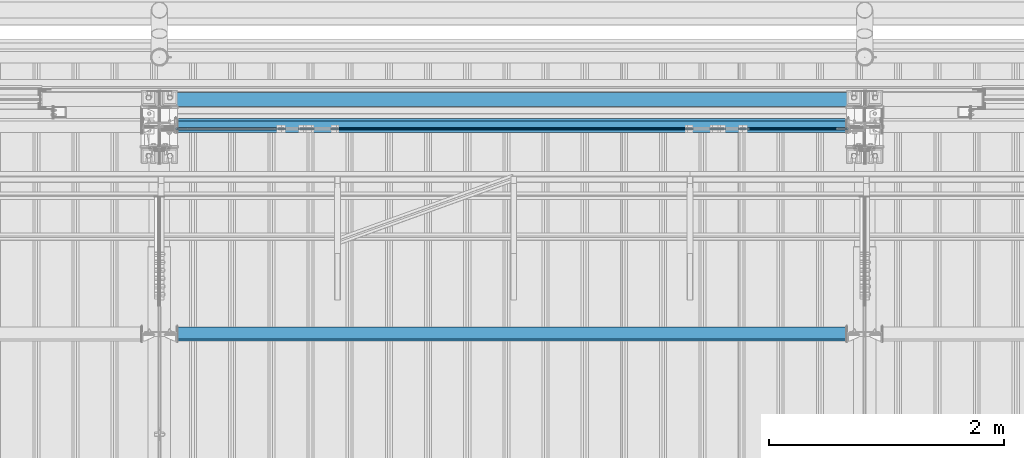
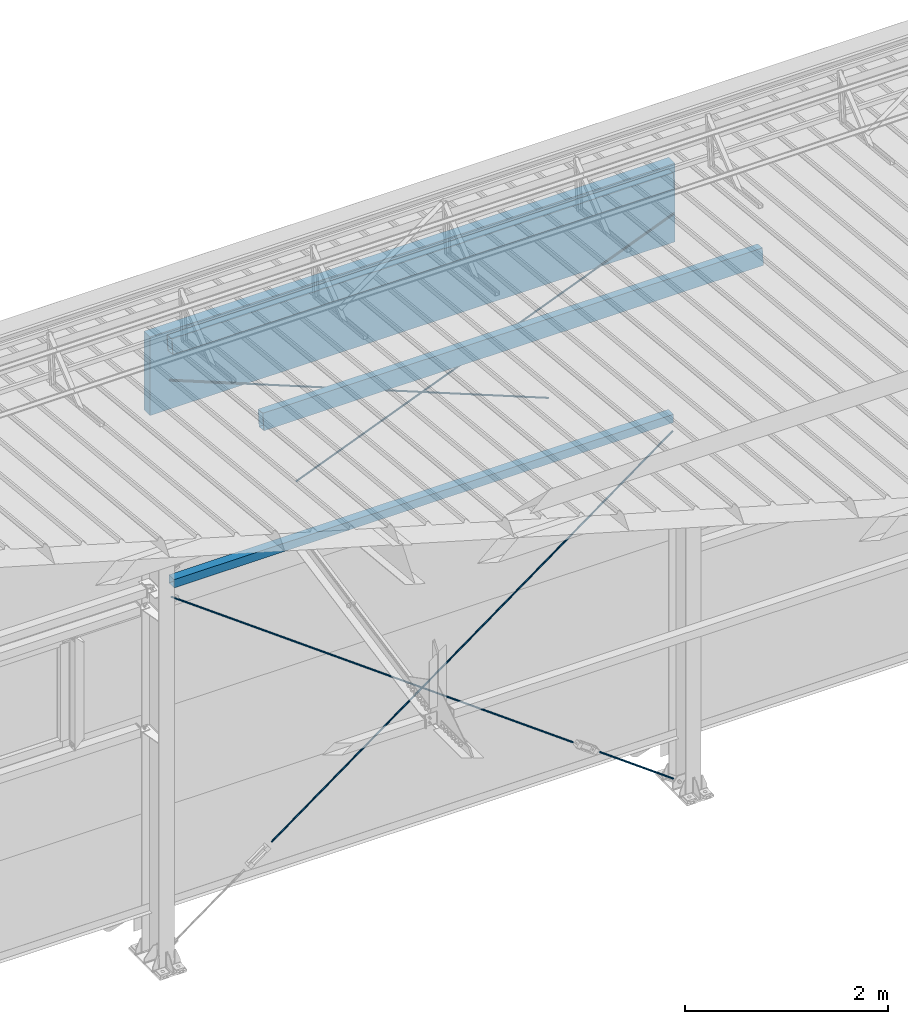
# One storey, part 270 of 709: 5 members, 4 beams, 5 openings, 9 elements without a shape of their own.
"""IFC4 building model written with IfcOpenShell, lengths in millimetres."""

import ifcopenshell
import ifcopenshell.guid

model = None  # the IFC model being written
_history = None  # IfcOwnerHistory: only IFC2X3 demands one
_inside = {}  # id of a spatial element -> (the spatial element, [elements in it])
_under = {}  # id of a project, library or spatial element -> (it, [spatial elements below it])
_declared = {}  # id of a project -> (the project, [libraries it declares])
_typed = {}  # id of a type object -> (the type object, [elements of that type])
_made_of = {}  # id of a material, layer set ... -> (it, [elements and type objects made of it])


def new_model(schema):
    """Start an empty IFC model of exactly this schema.

    Asked for "IFC4X3", IfcOpenShell would pick the latest addendum, in which some entities
    have other attributes; the version numbers below select the first issue.
    IFC2X3 requires an IfcOwnerHistory on every rooted entity: one is made here for all.
    """
    global model, _history
    if schema == "IFC4X3":
        model = ifcopenshell.file(schema_version=(4, 3, 0, 0))
    else:
        model = ifcopenshell.file(schema=schema)
    _inside.clear()
    _under.clear()
    _declared.clear()
    _typed.clear()
    _made_of.clear()
    _history = None
    if model.schema == "IFC2X3":
        org = make("IfcOrganization", Name="unknown")
        user = make(
            "IfcPersonAndOrganization",
            ThePerson=make("IfcPerson", FamilyName="unknown"),
            TheOrganization=org,
        )
        app = make(
            "IfcApplication",
            ApplicationDeveloper=org,
            Version="unknown",
            ApplicationFullName="unknown",
            ApplicationIdentifier="unknown",
        )
        _history = make(
            "IfcOwnerHistory",
            OwningUser=user,
            OwningApplication=app,
            ChangeAction="ADDED",
            CreationDate=0,
        )
    return model


def make(cls, **values):
    """One entity of the class cls with the attributes given. An attribute that is None is left unset."""
    return model.create_entity(
        cls, **{name: value for name, value in values.items() if value is not None}
    )


def rooted(cls, **values):
    """An entity with a GlobalId (a new one), such as an element, a storey or a relation."""
    return make(cls, GlobalId=ifcopenshell.guid.new(), OwnerHistory=_history, **values)


def si_unit(unit_type, name, prefix=None):
    """IfcSIUnit, for example si_unit("LENGTHUNIT", "METRE", prefix="MILLI")."""
    return make("IfcSIUnit", UnitType=unit_type, Prefix=prefix, Name=name)


def assignment(units):
    """IfcUnitAssignment: the units of a project."""
    return None if units is None else make("IfcUnitAssignment", Units=units)


def point(xyz):
    """IfcCartesianPoint."""
    return None if xyz is None else make("IfcCartesianPoint", Coordinates=xyz)


def direction(xyz):
    """IfcDirection."""
    return None if xyz is None else make("IfcDirection", DirectionRatios=xyz)


def frame(location, z_axis=None, x_axis=None):
    """IfcAxis2Placement3D, a coordinate frame: its origin and axes. An axis left out is left unset."""
    return make(
        "IfcAxis2Placement3D",
        Location=point(location),
        Axis=direction(z_axis),
        RefDirection=direction(x_axis),
    )


def origin_with_axes():
    """The frame at (0, 0, 0) with the z axis (0, 0, 1) and the x axis (1, 0, 0) written out."""
    return frame((0.0, 0.0, 0.0), z_axis=(0.0, 0.0, 1.0), x_axis=(1.0, 0.0, 0.0))


def place(relative_to, where):
    """IfcLocalPlacement: puts the frame where relative to a parent placement (None: the world)."""
    return make(
        "IfcLocalPlacement", PlacementRelTo=relative_to, RelativePlacement=where
    )


def context(
    kind, dimensions, precision=None, world=None, true_north=None, identifier=None
):
    """IfcGeometricRepresentationContext, for example the 3D "Model" context."""
    return make(
        "IfcGeometricRepresentationContext",
        ContextIdentifier=identifier,
        ContextType=kind,
        CoordinateSpaceDimension=dimensions,
        Precision=precision,
        WorldCoordinateSystem=world,
        TrueNorth=true_north,
    )


def subcontext(parent, identifier, kind, view, scale=None):
    """IfcGeometricRepresentationSubContext, for example "Body" below "Model"."""
    return make(
        "IfcGeometricRepresentationSubContext",
        ContextIdentifier=identifier,
        ContextType=kind,
        ParentContext=parent,
        TargetScale=scale,
        TargetView=view,
    )


def project(units=None, contexts=None):
    """IfcProject with its units and contexts."""
    return rooted(
        "IfcProject",
        Name="project",
        RepresentationContexts=contexts,
        UnitsInContext=assignment(units),
    )


def spatial(cls, under=None, at=None, **own):
    """A site, building, storey or space (cls), placed at a placement, below another one or the project."""
    s = rooted(cls, ObjectPlacement=at, **own)
    if under is not None:
        _under.setdefault(under.id(), (under, []))[1].append(s)
    return s


def point_list(points):
    """IfcCartesianPointList2D or 3D."""
    cls = (
        "IfcCartesianPointList2D" if len(points[0]) == 2 else "IfcCartesianPointList3D"
    )
    return make(cls, CoordList=points)


def line(*indices):
    """IfcLineIndex: a straight run through numbered points of an indexed curve."""
    return model.create_entity("IfcLineIndex", indices)


def indexed_curve(points, segments=None, self_intersect=None):
    """IfcIndexedPolyCurve: lines and arcs through numbered points (the first is 1)."""
    return make(
        "IfcIndexedPolyCurve",
        Points=point_list(points),
        Segments=segments,
        SelfIntersect=self_intersect,
    )


def outline(outer, holes=None, kind="AREA"):
    """IfcArbitraryClosedProfileDef: a profile drawn as a closed curve; with holes, ...WithVoids."""
    if holes is None:
        return make("IfcArbitraryClosedProfileDef", ProfileType=kind, OuterCurve=outer)
    return make(
        "IfcArbitraryProfileDefWithVoids",
        ProfileType=kind,
        OuterCurve=outer,
        InnerCurves=holes,
    )


def extrude(swept, where, along, depth):
    """IfcExtrudedAreaSolid: the profile swept, set in the frame where, extruded along a direction by depth."""
    return make(
        "IfcExtrudedAreaSolid",
        SweptArea=swept,
        Position=where,
        ExtrudedDirection=direction(along),
        Depth=depth,
    )


def polygons(points, faces, closed=None, point_numbers=None):
    """IfcPolygonalFaceSet: a face is its outer loop, then its inner loops; points numbered from 1."""
    made = []
    for loops in faces:
        if len(loops) == 1:
            made.append(make("IfcIndexedPolygonalFace", CoordIndex=loops[0]))
        else:
            made.append(
                make(
                    "IfcIndexedPolygonalFaceWithVoids",
                    CoordIndex=loops[0],
                    InnerCoordIndices=loops[1:],
                )
            )
    return make(
        "IfcPolygonalFaceSet",
        Coordinates=point_list(points),
        Closed=closed,
        Faces=made,
        PnIndex=point_numbers,
    )


def shape(context_of_items, identifier, shape_type, items):
    """IfcShapeRepresentation: the items that make up one representation, for example the "Body"."""
    return make(
        "IfcShapeRepresentation",
        ContextOfItems=context_of_items,
        RepresentationIdentifier=identifier,
        RepresentationType=shape_type,
        Items=items,
    )


def material(Name=None, Category=None):
    """IfcMaterial."""
    return make("IfcMaterial", Name=Name, Category=Category)


def made_of(thing, what):
    """Note that an element or type object is made of a material, layer set ...; save() writes the relation."""
    if what is not None:
        _made_of.setdefault(what.id(), (what, []))[1].append(thing)
    return thing


def element(
    cls,
    number,
    at=None,
    inside=None,
    cuts=None,
    type_object=None,
    material=None,
    context=None,
    identifier="Body",
    shape_type=None,
    held_by="IfcProductDefinitionShape",
    body=None,
    shapes=None,
    **own,
):
    """One element of the class cls, such as IfcWall. Its Tag is "e" and its number.

    at: its placement. inside: the storey or other place that contains it. cuts: it is an
    opening in that element (IfcRelVoidsElement). A single representation is given by context,
    identifier, shape_type and body (its items); several are given by shapes. held_by: the class
    of the entity that holds the representations. save() writes the other relations.
    """
    e = rooted(cls, Tag="e%d" % number, ObjectPlacement=at, **own)
    if body is not None:
        shapes = [shape(context, identifier, shape_type, body)]
    if shapes is not None:
        e.Representation = make(held_by, Representations=shapes)
    if inside is not None:
        _inside.setdefault(inside.id(), (inside, []))[1].append(e)
    if cuts is not None:
        rooted(
            "IfcRelVoidsElement", RelatingBuildingElement=cuts, RelatedOpeningElement=e
        )
    if type_object is not None:
        _typed.setdefault(type_object.id(), (type_object, []))[1].append(e)
    return made_of(e, material)


def aggregate(whole, parts):
    """IfcRelAggregates: a whole, such as a stair, and the parts it consists of."""
    return rooted("IfcRelAggregates", RelatingObject=whole, RelatedObjects=parts)


def save(model, path):
    """Write the relations noted so far, then the file.

    IfcRelAggregates (storeys below a building ...), IfcRelContainedInSpatialStructure (elements
    in a storey), IfcRelDefinesByType, IfcRelAssociatesMaterial and IfcRelDeclares: one each for
    every whole, place, type object, material and project.
    """
    for whole, parts in _under.values():
        aggregate(whole, parts)
    for where, things in _inside.values():
        rooted(
            "IfcRelContainedInSpatialStructure",
            RelatedElements=things,
            RelatingStructure=where,
        )
    for kind, things in _typed.values():
        rooted("IfcRelDefinesByType", RelatedObjects=things, RelatingType=kind)
    for what, things in _made_of.values():
        rooted("IfcRelAssociatesMaterial", RelatedObjects=things, RelatingMaterial=what)
    for by, libraries in _declared.values():
        rooted("IfcRelDeclares", RelatingContext=by, RelatedDefinitions=libraries)
    model.write(path)


model = new_model("IFC4")

# Units and contexts
model_context = context("Model", 3, precision=0.2, world=origin_with_axes(), true_north=direction((0.0, 1.0)))
body_context = subcontext(model_context, "Body", "Model", "MODEL_VIEW")
reference_context = subcontext(model_context, "Reference", "Model", "MODEL_VIEW")
ifc_project = project(units=[si_unit("LENGTHUNIT", "METRE", prefix="MILLI"), si_unit("AREAUNIT", "SQUARE_METRE"), si_unit("VOLUMEUNIT", "CUBIC_METRE"), si_unit("MASSUNIT", "GRAM", prefix="KILO"), si_unit("TIMEUNIT", "SECOND"), si_unit("PLANEANGLEUNIT", "RADIAN"), si_unit("SOLIDANGLEUNIT", "STERADIAN"), si_unit("THERMODYNAMICTEMPERATUREUNIT", "DEGREE_CELSIUS"), si_unit("LUMINOUSINTENSITYUNIT", "LUMEN")], contexts=[model_context])

# Site, building, storey
site_placement = place(None, origin_with_axes())
site = spatial("IfcSite", under=ifc_project, at=site_placement, CompositionType="ELEMENT")
building_placement = place(site_placement, origin_with_axes())
building = spatial("IfcBuilding", under=site, at=building_placement, Name="Undefined", CompositionType="ELEMENT")
storey_placement = place(building_placement, origin_with_axes())
storey = spatial("IfcBuildingStorey", under=building, at=storey_placement, Name="Undefined", CompositionType="ELEMENT", Elevation=0.0)

# Assembly, beam
assembly_1_placement = place(storey_placement, frame((28000.0, 21827.0, 4310.0), z_axis=(0.0, 0.0, -1.0), x_axis=(-1.0, 0.0, 0.0)))
assembly_1 = element("IfcElementAssembly", 1, at=assembly_1_placement, inside=storey)
ifc_material_1 = material(Name="C355", Category="STEEL")
beam_1_placement = place(assembly_1_placement, origin_with_axes())
beam_1 = element("IfcBeam", 2, at=beam_1_placement, material=ifc_material_1, ObjectType="546", context=body_context, shape_type="Tessellation", body=[
    polygons([(155.0, -47.0, -47.0), (155.0, -47.0, 47.0), (5845.0, -47.0, 47.0), (5845.0, -47.0, -47.0), (155.0, 47.0, 47.0), (5845.0, 47.0, 47.0), (155.0, 47.0, -47.0), (5845.0, 47.0, -47.0), (155.0, -50.0, -50.0), (155.0, 50.0, -50.0), (5845.0, 50.0, -50.0), (5845.0, -50.0, -50.0), (155.0, 50.0, 50.0), (5845.0, 50.0, 50.0), (155.0, -50.0, 50.0), (5845.0, -50.0, 50.0)], [[[1, 2, 3, 4]], [[2, 5, 6, 3]], [[5, 7, 8, 6]], [[7, 1, 4, 8]], [[9, 10, 11, 12]], [[10, 13, 14, 11]], [[13, 15, 16, 14]], [[15, 9, 12, 16]], [[14, 16, 12, 11], [6, 8, 4, 3]], [[15, 13, 10, 9], [7, 5, 2, 1]]], closed=True),
])
aggregate(assembly_1, [beam_1])

# Assembly, member, voiding feature
assembly_2_placement = place(storey_placement, frame((28000.0, 21811.0, -155.0), z_axis=(0.0, 1.0, 0.0), x_axis=(-0.8064830392, 0.0, 0.5912572262)))
assembly_2 = element("IfcElementAssembly", 3, at=assembly_2_placement, inside=storey)
ifc_material_2 = material(Name="C355-5", Category="STEEL")
member_1_placement = place(assembly_2_placement, origin_with_axes())
member_1 = element("IfcMember", 4, at=member_1_placement, material=ifc_material_2, ObjectType="548", context=body_context, shape_type="Tessellation", body=[
    polygons([(1390.0, 7.36122, 4.25), (1390.0, 6.01041, 6.01041), (1390.0, 4.25, 7.36122), (1390.0, 2.19996, 8.21037), (1390.0, 0.0, 8.5), (1390.0, -2.19996, 8.21037), (1390.0, -4.25, 7.36122), (1390.0, -6.01041, 6.01041), (1390.0, -7.36122, 4.25), (1390.0, -8.21037, 2.19996), (1390.0, -8.5, 0.0), (1390.0, -8.21037, -2.19996), (1390.0, -7.36122, -4.25), (1390.0, -6.01041, -6.01041), (1390.0, -4.25, -7.36122), (1390.0, -2.19996, -8.21037), (1390.0, 0.0, -8.5), (1390.0, 2.19996, -8.21037), (1390.0, 4.25, -7.36122), (1390.0, 6.01041, -6.01041), (1390.0, 7.36122, -4.25), (1390.0, 8.21037, -2.19996), (1390.0, 8.5, 0.0), (1390.0, 8.21037, 2.19996), (1210.0, 8.21037, 2.19996), (1210.0, 7.36122, 4.25), (1210.0, 6.01041, 6.01041), (1210.0, 4.25, 7.36122), (1210.0, 2.19996, 8.21037), (1210.0, 0.0, 8.5), (1210.0, -2.19996, 8.21037), (1210.0, -4.25, 7.36122), (1210.0, -6.01041, 6.01041), (1210.0, -7.36122, 4.25), (1210.0, -8.21037, 2.19996), (1210.0, -8.5, 0.0), (1210.0, -8.21037, -2.19996), (1210.0, -7.36122, -4.25), (1210.0, -6.01041, -6.01041), (1210.0, -4.25, -7.36122), (1210.0, -2.19996, -8.21037), (1210.0, 0.0, -8.5), (1210.0, 2.19996, -8.21037), (1210.0, 4.25, -7.36122), (1210.0, 6.01041, -6.01041), (1210.0, 7.36122, -4.25), (1210.0, 8.21037, -2.19996), (1210.0, 8.5, 0.0), (1210.0, 10.0, 0.0), (1210.0, 9.65926, 2.58819), (1210.0, 8.66025, 5.0), (1210.0, 7.07107, 7.07107), (1210.0, 5.0, 8.66025), (1210.0, 2.58819, 9.65926), (1210.0, 0.0, 10.0), (1210.0, -2.58819, 9.65926), (1210.0, -5.0, 8.66025), (1210.0, -7.07107, 7.07107), (1210.0, -8.66025, 5.0), (1210.0, -9.65926, 2.58819), (1210.0, -10.0, 0.0), (1210.0, -9.65926, -2.58819), (1210.0, -8.66025, -5.0), (1210.0, -7.07107, -7.07107), (1210.0, -5.0, -8.66025), (1210.0, -2.58819, -9.65926), (1210.0, 0.0, -10.0), (1210.0, 2.58819, -9.65926), (1210.0, 5.0, -8.66025), (1210.0, 7.07107, -7.07107), (1210.0, 8.66025, -5.0), (1210.0, 9.65926, -2.58819), (174.17845, 2.58819, 9.65926), (174.17845, 5.0, 8.66025), (174.17845, 7.07107, 7.07107), (174.17845, 8.66025, 5.0), (174.17845, 9.65926, 2.58819), (174.17845, 10.0, 0.0), (174.17845, 9.65926, -2.58819), (174.17845, 8.66025, -5.0), (174.17845, 7.07107, -7.07107), (174.17845, 5.0, -8.66025), (174.17845, 2.58819, -9.65926), (174.17845, 0.0, -10.0), (174.17845, -2.58819, -9.65926), (174.17845, -5.0, -8.66025), (174.17845, -7.07107, -7.07107), (174.17845, -8.66025, -5.0), (174.17845, -9.65926, -2.58819), (174.17845, -10.0, 0.0), (174.17845, -9.65926, 2.58819), (174.17845, -8.66025, 5.0), (174.17845, -7.07107, 7.07107), (174.17845, -5.0, 8.66025), (174.17845, -2.58819, 9.65926), (174.17845, 0.0, 10.0)], [[[1, 2, 3, 4, 5, 6, 7, 8, 9, 10, 11, 12, 13, 14, 15, 16, 17, 18, 19, 20, 21, 22, 23, 24]], [[24, 25, 26, 1]], [[1, 26, 27, 2]], [[2, 27, 28, 3]], [[3, 28, 29, 4]], [[4, 29, 30, 5]], [[5, 30, 31, 6]], [[6, 31, 32, 7]], [[7, 32, 33, 8]], [[8, 33, 34, 9]], [[9, 34, 35, 10]], [[10, 35, 36, 11]], [[11, 36, 37, 12]], [[12, 37, 38, 13]], [[13, 38, 39, 14]], [[14, 39, 40, 15]], [[15, 40, 41, 16]], [[16, 41, 42, 17]], [[17, 42, 43, 18]], [[18, 43, 44, 19]], [[19, 44, 45, 20]], [[20, 45, 46, 21]], [[21, 46, 47, 22]], [[22, 47, 48, 23]], [[23, 48, 25, 24]], [[49, 50, 51, 52, 53, 54, 55, 56, 57, 58, 59, 60, 61, 62, 63, 64, 65, 66, 67, 68, 69, 70, 71, 72], [47, 46, 45, 44, 43, 42, 41, 40, 39, 38, 37, 36, 35, 34, 33, 32, 31, 30, 29, 28, 27, 26, 25, 48]], [[73, 74, 75, 76, 77, 78, 79, 80, 81, 82, 83, 84, 85, 86, 87, 88, 89, 90, 91, 92, 93, 94, 95, 96]], [[79, 78, 49, 72]], [[80, 79, 72, 71]], [[81, 80, 71, 70]], [[82, 81, 70, 69]], [[83, 82, 69, 68]], [[84, 83, 68, 67]], [[85, 84, 67, 66]], [[86, 85, 66, 65]], [[87, 86, 65, 64]], [[88, 87, 64, 63]], [[89, 88, 63, 62]], [[90, 89, 62, 61]], [[91, 90, 61, 60]], [[92, 91, 60, 59]], [[93, 92, 59, 58]], [[94, 93, 58, 57]], [[95, 94, 57, 56]], [[96, 95, 56, 55]], [[73, 96, 55, 54]], [[74, 73, 54, 53]], [[75, 74, 53, 52]], [[76, 75, 52, 51]], [[77, 76, 51, 50]], [[78, 77, 50, 49]]], closed=True),
])
voiding_feature_1_placement = place(member_1_placement, frame((1390.0, 0.0, 0.0), z_axis=(0.0, 1.0, 0.0), x_axis=(-1.0, 0.0, 0.0)))
element("IfcVoidingFeature", 5, at=voiding_feature_1_placement, cuts=member_1, PredefinedType="HOLE", context=reference_context, identifier="Reference", shape_type="SolidModel", body=[
    extrude(outline(indexed_curve([(10.5, 0.0), (10.14222, 2.7176), (9.09327, 5.25), (7.42462, 7.42462), (5.25, 9.09327), (2.7176, 10.14222), (0.0, 10.5), (-2.7176, 10.14222), (-5.25, 9.09327), (-7.42462, 7.42462), (-9.09327, 5.25), (-10.14222, 2.7176), (-10.5, 0.0), (-10.14222, -2.7176), (-9.09327, -5.25), (-7.42462, -7.42462), (-5.25, -9.09327), (-2.7176, -10.14222), (0.0, -10.5), (2.7176, -10.14222), (5.25, -9.09327), (7.42462, -7.42462), (9.09327, -5.25), (10.14222, -2.7176)], segments=[line(1, 2, 3, 4, 5, 6, 7, 8, 9, 10, 11, 12, 13, 14, 15, 16, 17, 18, 19, 20, 21, 22, 23, 24, 1)])), frame((0.0, 0.0, 0.0), z_axis=(-1.0, 0.0, 0.0), x_axis=(0.0, 0.0, 1.0)), (0.0, 0.0, -1.0), 180.0),
])
aggregate(assembly_2, [member_1])

assembly_3_placement = place(storey_placement, frame((26870.92374, 21811.0, 672.76012), z_axis=(0.0, 1.0, 0.0), x_axis=(-0.8064830392, 0.0, 0.5912572262)))
assembly_3 = element("IfcElementAssembly", 6, at=assembly_3_placement, inside=storey)
member_2_placement = place(assembly_3_placement, origin_with_axes())
member_2 = element("IfcMember", 7, at=member_2_placement, material=ifc_material_2, ObjectType="549", context=body_context, shape_type="Tessellation", body=[
    polygons([(5861.83429, -5.0, 8.66025), (5861.83429, -7.07107, 7.07107), (5861.83429, -8.66025, 5.0), (5861.83429, -9.65926, 2.58819), (5861.83429, -10.0, 0.0), (5861.83429, -9.65926, -2.58819), (5861.83429, -8.66025, -5.0), (5861.83429, -7.07107, -7.07107), (5861.83429, -5.0, -8.66025), (5861.83429, -2.58819, -9.65926), (5861.83429, 0.0, -10.0), (5861.83429, 2.58819, -9.65926), (5861.83429, 5.0, -8.66025), (5861.83429, 7.07107, -7.07107), (5861.83429, 8.66025, -5.0), (5861.83429, 9.65926, -2.58819), (5861.83429, 10.0, 0.0), (5861.83429, 9.65926, 2.58819), (5861.83429, 8.66025, 5.0), (5861.83429, 7.07107, 7.07107), (5861.83429, 5.0, 8.66025), (5861.83429, 2.58819, 9.65926), (5861.83429, 0.0, 10.0), (5861.83429, -2.58819, 9.65926), (190.0, 10.0, 0.0), (190.0, 9.65926, 2.58819), (190.0, 8.66025, 5.0), (190.0, 7.07107, 7.07107), (190.0, 5.0, 8.66025), (190.0, 2.58819, 9.65926), (190.0, 0.0, 10.0), (190.0, -2.58819, 9.65926), (190.0, -5.0, 8.66025), (190.0, -7.07107, 7.07107), (190.0, -8.66025, 5.0), (190.0, -9.65926, 2.58819), (190.0, -10.0, 0.0), (190.0, -9.65926, -2.58819), (190.0, -8.66025, -5.0), (190.0, -7.07107, -7.07107), (190.0, -5.0, -8.66025), (190.0, -2.58819, -9.65926), (190.0, 0.0, -10.0), (190.0, 2.58819, -9.65926), (190.0, 5.0, -8.66025), (190.0, 7.07107, -7.07107), (190.0, 8.66025, -5.0), (190.0, 9.65926, -2.58819), (10.0, 7.36122, 4.25), (190.0, 7.36122, 4.25), (190.0, 8.21037, 2.19996), (10.0, 8.21037, 2.19996), (10.0, 6.01041, 6.01041), (190.0, 6.01041, 6.01041), (10.0, 4.25, 7.36122), (190.0, 4.25, 7.36122), (10.0, 2.19996, 8.21037), (190.0, 2.19996, 8.21037), (10.0, 0.0, 8.5), (190.0, 0.0, 8.5), (10.0, -2.19996, 8.21037), (190.0, -2.19996, 8.21037), (10.0, -4.25, 7.36122), (190.0, -4.25, 7.36122), (10.0, -6.01041, 6.01041), (190.0, -6.01041, 6.01041), (10.0, -7.36122, 4.25), (190.0, -7.36122, 4.25), (10.0, -8.21037, 2.19996), (190.0, -8.21037, 2.19996), (10.0, -8.5, 0.0), (190.0, -8.5, 0.0), (10.0, -8.21037, -2.19996), (190.0, -8.21037, -2.19996), (10.0, -7.36122, -4.25), (190.0, -7.36122, -4.25), (10.0, -6.01041, -6.01041), (190.0, -6.01041, -6.01041), (10.0, -4.25, -7.36122), (190.0, -4.25, -7.36122), (10.0, -2.19996, -8.21037), (190.0, -2.19996, -8.21037), (10.0, 0.0, -8.5), (190.0, 0.0, -8.5), (10.0, 2.19996, -8.21037), (190.0, 2.19996, -8.21037), (10.0, 4.25, -7.36122), (190.0, 4.25, -7.36122), (10.0, 6.01041, -6.01041), (190.0, 6.01041, -6.01041), (10.0, 7.36122, -4.25), (190.0, 7.36122, -4.25), (10.0, 8.21037, -2.19996), (190.0, 8.21037, -2.19996), (10.0, 8.5, 0.0), (190.0, 8.5, 0.0)], [[[1, 2, 3, 4, 5, 6, 7, 8, 9, 10, 11, 12, 13, 14, 15, 16, 17, 18, 19, 20, 21, 22, 23, 24]], [[18, 17, 25, 26]], [[19, 18, 26, 27]], [[20, 19, 27, 28]], [[21, 20, 28, 29]], [[22, 21, 29, 30]], [[23, 22, 30, 31]], [[24, 23, 31, 32]], [[1, 24, 32, 33]], [[2, 1, 33, 34]], [[3, 2, 34, 35]], [[4, 3, 35, 36]], [[5, 4, 36, 37]], [[6, 5, 37, 38]], [[7, 6, 38, 39]], [[8, 7, 39, 40]], [[9, 8, 40, 41]], [[10, 9, 41, 42]], [[11, 10, 42, 43]], [[12, 11, 43, 44]], [[13, 12, 44, 45]], [[14, 13, 45, 46]], [[15, 14, 46, 47]], [[16, 15, 47, 48]], [[17, 16, 48, 25]], [[25, 48, 47, 46, 45, 44, 43, 42, 41, 40, 39, 38, 37, 36, 35, 34, 33, 32, 31, 30, 29, 28, 27, 26], [74, 76, 78, 80, 82, 84, 86, 88, 90, 92, 94, 96, 51, 50, 54, 56, 58, 60, 62, 64, 66, 68, 70, 72]], [[49, 50, 51, 52]], [[53, 54, 50, 49]], [[55, 56, 54, 53]], [[57, 58, 56, 55]], [[59, 60, 58, 57]], [[61, 62, 60, 59]], [[63, 64, 62, 61]], [[65, 66, 64, 63]], [[67, 68, 66, 65]], [[69, 70, 68, 67]], [[71, 72, 70, 69]], [[73, 74, 72, 71]], [[75, 76, 74, 73]], [[77, 78, 76, 75]], [[79, 80, 78, 77]], [[81, 82, 80, 79]], [[83, 84, 82, 81]], [[85, 86, 84, 83]], [[87, 88, 86, 85]], [[89, 90, 88, 87]], [[91, 92, 90, 89]], [[93, 94, 92, 91]], [[95, 96, 94, 93]], [[52, 51, 96, 95]], [[91, 89, 87, 85, 83, 81, 79, 77, 75, 73, 71, 69, 67, 65, 63, 61, 59, 57, 55, 53, 49, 52, 95, 93]]], closed=True),
])
voiding_feature_2_placement = place(member_2_placement, frame((10.0, 0.0, 0.0), z_axis=(0.0, -1.0, 0.0), x_axis=(1.0, 0.0, 0.0)))
element("IfcVoidingFeature", 8, at=voiding_feature_2_placement, cuts=member_2, PredefinedType="HOLE", context=reference_context, identifier="Reference", shape_type="SolidModel", body=[
    extrude(outline(indexed_curve([(10.5, 0.0), (10.14222, 2.7176), (9.09327, 5.25), (7.42462, 7.42462), (5.25, 9.09327), (2.7176, 10.14222), (0.0, 10.5), (-2.7176, 10.14222), (-5.25, 9.09327), (-7.42462, 7.42462), (-9.09327, 5.25), (-10.14222, 2.7176), (-10.5, 0.0), (-10.14222, -2.7176), (-9.09327, -5.25), (-7.42462, -7.42462), (-5.25, -9.09327), (-2.7176, -10.14222), (0.0, -10.5), (2.7176, -10.14222), (5.25, -9.09327), (7.42462, -7.42462), (9.09327, -5.25), (10.14222, -2.7176)], segments=[line(1, 2, 3, 4, 5, 6, 7, 8, 9, 10, 11, 12, 13, 14, 15, 16, 17, 18, 19, 20, 21, 22, 23, 24, 1)])), frame((0.0, 0.0, 0.0), z_axis=(-1.0, 0.0, 0.0), x_axis=(0.0, 0.0, 1.0)), (0.0, 0.0, -1.0), 180.0),
])
aggregate(assembly_3, [member_2])

assembly_4_placement = place(storey_placement, frame((27913.0, 21811.0, 4180.0), z_axis=(0.0, 1.0, 0.0), x_axis=(-0.8064830392, 0.0, -0.5912572261)))
assembly_4 = element("IfcElementAssembly", 9, at=assembly_4_placement, inside=storey)
member_3_placement = place(assembly_4_placement, origin_with_axes())
member_3 = element("IfcMember", 10, at=member_3_placement, material=ifc_material_2, ObjectType="549", context=body_context, shape_type="Tessellation", body=[
    polygons([(5921.83429, 7.36122, 4.25), (5921.83429, 6.01041, 6.01041), (5921.83429, 4.25, 7.36122), (5921.83429, 2.19996, 8.21037), (5921.83429, 0.0, 8.5), (5921.83429, -2.19996, 8.21037), (5921.83429, -4.25, 7.36122), (5921.83429, -6.0104, 6.01041), (5921.83429, -7.36121, 4.25), (5921.83429, -8.21037, 2.19996), (5921.83429, -8.5, 0.0), (5921.83429, -8.21037, -2.19996), (5921.83429, -7.36121, -4.25), (5921.83429, -6.0104, -6.01041), (5921.83429, -4.25, -7.36122), (5921.83429, -2.19996, -8.21037), (5921.83429, 0.0, -8.5), (5921.83429, 2.19996, -8.21037), (5921.83429, 4.25, -7.36122), (5921.83429, 6.01041, -6.01041), (5921.83429, 7.36122, -4.25), (5921.83429, 8.21037, -2.19996), (5921.83429, 8.5, 0.0), (5921.83429, 8.21037, 2.19996), (5741.83429, 8.21037, 2.19996), (5741.83429, 7.36122, 4.25), (5741.83429, 6.01041, 6.01041), (5741.83429, 4.25, 7.36122), (5741.83429, 2.19996, 8.21037), (5741.83429, 0.0, 8.5), (5741.83429, -2.19996, 8.21037), (5741.83429, -4.25, 7.36122), (5741.83429, -6.0104, 6.01041), (5741.83429, -7.36121, 4.25), (5741.83429, -8.21037, 2.19996), (5741.83429, -8.5, 0.0), (5741.83429, -8.21037, -2.19996), (5741.83429, -7.36121, -4.25), (5741.83429, -6.0104, -6.01041), (5741.83429, -4.25, -7.36122), (5741.83429, -2.19996, -8.21037), (5741.83429, 0.0, -8.5), (5741.83429, 2.19996, -8.21037), (5741.83429, 4.25, -7.36122), (5741.83429, 6.01041, -6.01041), (5741.83429, 7.36122, -4.25), (5741.83429, 8.21037, -2.19996), (5741.83429, 8.5, 0.0), (5741.83429, 10.0, 0.0), (5741.83429, 9.65926, 2.58819), (5741.83429, 8.66025, 5.0), (5741.83429, 7.07107, 7.07107), (5741.83429, 5.0, 8.66025), (5741.83429, 2.58819, 9.65926), (5741.83429, 0.0, 10.0), (5741.83429, -2.58819, 9.65926), (5741.83429, -5.0, 8.66025), (5741.83429, -7.07107, 7.07107), (5741.83429, -8.66025, 5.0), (5741.83429, -9.65926, 2.58819), (5741.83429, -10.0, 0.0), (5741.83429, -9.65926, -2.58819), (5741.83429, -8.66025, -5.0), (5741.83429, -7.07107, -7.07107), (5741.83429, -5.0, -8.66025), (5741.83429, -2.58819, -9.65926), (5741.83429, 0.0, -10.0), (5741.83429, 2.58819, -9.65926), (5741.83429, 5.0, -8.66025), (5741.83429, 7.07107, -7.07107), (5741.83429, 8.66025, -5.0), (5741.83429, 9.65926, -2.58819), (70.0, 2.58819, 9.65926), (70.0, 5.0, 8.66025), (70.0, 7.07107, 7.07107), (70.0, 8.66025, 5.0), (70.0, 9.65926, 2.58819), (70.0, 10.0, 0.0), (70.0, 9.65926, -2.58819), (70.0, 8.66025, -5.0), (70.0, 7.07107, -7.07107), (70.0, 5.0, -8.66025), (70.0, 2.58819, -9.65926), (70.0, 0.0, -10.0), (70.0, -2.58819, -9.65926), (70.0, -5.0, -8.66025), (70.0, -7.07107, -7.07107), (70.0, -8.66025, -5.0), (70.0, -9.65926, -2.58819), (70.0, -10.0, 0.0), (70.0, -9.65926, 2.58819), (70.0, -8.66025, 5.0), (70.0, -7.07107, 7.07107), (70.0, -5.0, 8.66025), (70.0, -2.58819, 9.65926), (70.0, 0.0, 10.0)], [[[1, 2, 3, 4, 5, 6, 7, 8, 9, 10, 11, 12, 13, 14, 15, 16, 17, 18, 19, 20, 21, 22, 23, 24]], [[24, 25, 26, 1]], [[1, 26, 27, 2]], [[2, 27, 28, 3]], [[3, 28, 29, 4]], [[4, 29, 30, 5]], [[5, 30, 31, 6]], [[6, 31, 32, 7]], [[7, 32, 33, 8]], [[8, 33, 34, 9]], [[9, 34, 35, 10]], [[10, 35, 36, 11]], [[11, 36, 37, 12]], [[12, 37, 38, 13]], [[13, 38, 39, 14]], [[14, 39, 40, 15]], [[15, 40, 41, 16]], [[16, 41, 42, 17]], [[17, 42, 43, 18]], [[18, 43, 44, 19]], [[19, 44, 45, 20]], [[20, 45, 46, 21]], [[21, 46, 47, 22]], [[22, 47, 48, 23]], [[23, 48, 25, 24]], [[49, 50, 51, 52, 53, 54, 55, 56, 57, 58, 59, 60, 61, 62, 63, 64, 65, 66, 67, 68, 69, 70, 71, 72], [47, 46, 45, 44, 43, 42, 41, 40, 39, 38, 37, 36, 35, 34, 33, 32, 31, 30, 29, 28, 27, 26, 25, 48]], [[73, 74, 75, 76, 77, 78, 79, 80, 81, 82, 83, 84, 85, 86, 87, 88, 89, 90, 91, 92, 93, 94, 95, 96]], [[79, 78, 49, 72]], [[80, 79, 72, 71]], [[81, 80, 71, 70]], [[82, 81, 70, 69]], [[83, 82, 69, 68]], [[84, 83, 68, 67]], [[85, 84, 67, 66]], [[86, 85, 66, 65]], [[87, 86, 65, 64]], [[88, 87, 64, 63]], [[89, 88, 63, 62]], [[90, 89, 62, 61]], [[91, 90, 61, 60]], [[92, 91, 60, 59]], [[93, 92, 59, 58]], [[94, 93, 58, 57]], [[95, 94, 57, 56]], [[96, 95, 56, 55]], [[73, 96, 55, 54]], [[74, 73, 54, 53]], [[75, 74, 53, 52]], [[76, 75, 52, 51]], [[77, 76, 51, 50]], [[78, 77, 50, 49]]], closed=True),
])
voiding_feature_3_placement = place(member_3_placement, frame((5921.83429, 0.0, 0.0), z_axis=(0.0, 1.0, 0.0), x_axis=(-1.0, 0.0, 0.0)))
element("IfcVoidingFeature", 11, at=voiding_feature_3_placement, cuts=member_3, PredefinedType="HOLE", context=reference_context, identifier="Reference", shape_type="SolidModel", body=[
    extrude(outline(indexed_curve([(10.5, 0.0), (10.14222, 2.7176), (9.09327, 5.25), (7.42462, 7.42462), (5.25, 9.09327), (2.7176, 10.14222), (0.0, 10.5), (-2.7176, 10.14222), (-5.25, 9.09327), (-7.42462, 7.42462), (-9.09327, 5.25), (-10.14222, 2.7176), (-10.5, 0.0), (-10.14222, -2.7176), (-9.09327, -5.25), (-7.42462, -7.42462), (-5.25, -9.09327), (-2.7176, -10.14222), (0.0, -10.5), (2.7176, -10.14222), (5.25, -9.09327), (7.42462, -7.42462), (9.09327, -5.25), (10.14222, -2.7176)], segments=[line(1, 2, 3, 4, 5, 6, 7, 8, 9, 10, 11, 12, 13, 14, 15, 16, 17, 18, 19, 20, 21, 22, 23, 24, 1)])), frame((0.0, 0.0, 0.0), z_axis=(-1.0, 0.0, 0.0), x_axis=(0.0, 0.0, 1.0)), (0.0, 0.0, -1.0), 180.0),
])
aggregate(assembly_4, [member_3])

assembly_5_placement = place(storey_placement, frame((26612.9509, 21811.0, 4959.49238), z_axis=(0.0, 1.0, 0.0), x_axis=(-0.9286065, 0.0, 0.371065989)))
assembly_5 = element("IfcElementAssembly", 12, at=assembly_5_placement, inside=storey)
member_4_placement = place(assembly_5_placement, origin_with_axes())
member_4 = element("IfcMember", 13, at=member_4_placement, material=ifc_material_2, ObjectType="550", context=body_context, shape_type="Tessellation", body=[
    polygons([(4830.84953, -5.0, 8.66025), (4830.84953, -7.07107, 7.07107), (4830.84953, -8.66025, 5.0), (4830.84953, -9.65926, 2.58819), (4830.84953, -10.0, 0.0), (4830.84953, -9.65926, -2.58819), (4830.84953, -8.66025, -5.0), (4830.84953, -7.07107, -7.07107), (4830.84953, -5.0, -8.66025), (4830.84953, -2.58819, -9.65926), (4830.84953, 0.0, -10.0), (4830.84953, 2.58819, -9.65926), (4830.84953, 5.0, -8.66025), (4830.84953, 7.07107, -7.07107), (4830.84953, 8.66025, -5.0), (4830.84953, 9.65926, -2.58819), (4830.84953, 10.0, 0.0), (4830.84953, 9.65926, 2.58819), (4830.84953, 8.66025, 5.0), (4830.84953, 7.07107, 7.07107), (4830.84953, 5.0, 8.66025), (4830.84953, 2.58819, 9.65926), (4830.84953, 0.0, 10.0), (4830.84953, -2.58819, 9.65926), (190.0, 10.0, 0.0), (190.0, 9.65926, 2.58819), (190.0, 8.66025, 5.0), (190.0, 7.07107, 7.07107), (190.0, 5.0, 8.66025), (190.0, 2.58819, 9.65926), (190.0, 0.0, 10.0), (190.0, -2.58819, 9.65926), (190.0, -5.0, 8.66025), (190.0, -7.07107, 7.07107), (190.0, -8.66025, 5.0), (190.0, -9.65926, 2.58819), (190.0, -10.0, 0.0), (190.0, -9.65926, -2.58819), (190.0, -8.66025, -5.0), (190.0, -7.07107, -7.07107), (190.0, -5.0, -8.66025), (190.0, -2.58819, -9.65926), (190.0, 0.0, -10.0), (190.0, 2.58819, -9.65926), (190.0, 5.0, -8.66025), (190.0, 7.07107, -7.07107), (190.0, 8.66025, -5.0), (190.0, 9.65926, -2.58819), (10.0, 7.36122, 4.25), (190.0, 7.36122, 4.25), (190.0, 8.21037, 2.19996), (10.0, 8.21037, 2.19996), (10.0, 6.01041, 6.01041), (190.0, 6.01041, 6.01041), (10.0, 4.25, 7.36122), (190.0, 4.25, 7.36122), (10.0, 2.19996, 8.21037), (190.0, 2.19996, 8.21037), (10.0, 0.0, 8.5), (190.0, 0.0, 8.5), (10.0, -2.19996, 8.21037), (190.0, -2.19996, 8.21037), (10.0, -4.25, 7.36122), (190.0, -4.25, 7.36122), (10.0, -6.01041, 6.01041), (190.0, -6.01041, 6.01041), (10.0, -7.36122, 4.25), (190.0, -7.36122, 4.25), (10.0, -8.21037, 2.19996), (190.0, -8.21037, 2.19996), (10.0, -8.5, 0.0), (190.0, -8.5, 0.0), (10.0, -8.21037, -2.19996), (190.0, -8.21037, -2.19996), (10.0, -7.36122, -4.25), (190.0, -7.36122, -4.25), (10.0, -6.01041, -6.01041), (190.0, -6.01041, -6.01041), (10.0, -4.25, -7.36122), (190.0, -4.25, -7.36122), (10.0, -2.19996, -8.21037), (190.0, -2.19996, -8.21037), (10.0, 0.0, -8.5), (190.0, 0.0, -8.5), (10.0, 2.19996, -8.21037), (190.0, 2.19996, -8.21037), (10.0, 4.25, -7.36122), (190.0, 4.25, -7.36122), (10.0, 6.01041, -6.01041), (190.0, 6.01041, -6.01041), (10.0, 7.36122, -4.25), (190.0, 7.36122, -4.25), (10.0, 8.21037, -2.19996), (190.0, 8.21037, -2.19996), (10.0, 8.5, 0.0), (190.0, 8.5, 0.0)], [[[1, 2, 3, 4, 5, 6, 7, 8, 9, 10, 11, 12, 13, 14, 15, 16, 17, 18, 19, 20, 21, 22, 23, 24]], [[18, 17, 25, 26]], [[19, 18, 26, 27]], [[20, 19, 27, 28]], [[21, 20, 28, 29]], [[22, 21, 29, 30]], [[23, 22, 30, 31]], [[24, 23, 31, 32]], [[1, 24, 32, 33]], [[2, 1, 33, 34]], [[3, 2, 34, 35]], [[4, 3, 35, 36]], [[5, 4, 36, 37]], [[6, 5, 37, 38]], [[7, 6, 38, 39]], [[8, 7, 39, 40]], [[9, 8, 40, 41]], [[10, 9, 41, 42]], [[11, 10, 42, 43]], [[12, 11, 43, 44]], [[13, 12, 44, 45]], [[14, 13, 45, 46]], [[15, 14, 46, 47]], [[16, 15, 47, 48]], [[17, 16, 48, 25]], [[25, 48, 47, 46, 45, 44, 43, 42, 41, 40, 39, 38, 37, 36, 35, 34, 33, 32, 31, 30, 29, 28, 27, 26], [74, 76, 78, 80, 82, 84, 86, 88, 90, 92, 94, 96, 51, 50, 54, 56, 58, 60, 62, 64, 66, 68, 70, 72]], [[49, 50, 51, 52]], [[53, 54, 50, 49]], [[55, 56, 54, 53]], [[57, 58, 56, 55]], [[59, 60, 58, 57]], [[61, 62, 60, 59]], [[63, 64, 62, 61]], [[65, 66, 64, 63]], [[67, 68, 66, 65]], [[69, 70, 68, 67]], [[71, 72, 70, 69]], [[73, 74, 72, 71]], [[75, 76, 74, 73]], [[77, 78, 76, 75]], [[79, 80, 78, 77]], [[81, 82, 80, 79]], [[83, 84, 82, 81]], [[85, 86, 84, 83]], [[87, 88, 86, 85]], [[89, 90, 88, 87]], [[91, 92, 90, 89]], [[93, 94, 92, 91]], [[95, 96, 94, 93]], [[52, 51, 96, 95]], [[91, 89, 87, 85, 83, 81, 79, 77, 75, 73, 71, 69, 67, 65, 63, 61, 59, 57, 55, 53, 49, 52, 95, 93]]], closed=True),
])
voiding_feature_4_placement = place(member_4_placement, frame((10.0, 0.0, 0.0), z_axis=(0.0, -1.0, 0.0), x_axis=(1.0, 0.0, 0.0)))
element("IfcVoidingFeature", 14, at=voiding_feature_4_placement, cuts=member_4, PredefinedType="HOLE", context=reference_context, identifier="Reference", shape_type="SolidModel", body=[
    extrude(outline(indexed_curve([(10.5, 0.0), (10.14222, 2.7176), (9.09327, 5.25), (7.42462, 7.42462), (5.25, 9.09327), (2.7176, 10.14222), (0.0, 10.5), (-2.7176, 10.14222), (-5.25, 9.09327), (-7.42462, 7.42462), (-9.09327, 5.25), (-10.14222, 2.7176), (-10.5, 0.0), (-10.14222, -2.7176), (-9.09327, -5.25), (-7.42462, -7.42462), (-5.25, -9.09327), (-2.7176, -10.14222), (0.0, -10.5), (2.7176, -10.14222), (5.25, -9.09327), (7.42462, -7.42462), (9.09327, -5.25), (10.14222, -2.7176)], segments=[line(1, 2, 3, 4, 5, 6, 7, 8, 9, 10, 11, 12, 13, 14, 15, 16, 17, 18, 19, 20, 21, 22, 23, 24, 1)])), frame((0.0, 0.0, 0.0), z_axis=(-1.0, 0.0, 0.0), x_axis=(0.0, 0.0, 1.0)), (0.0, 0.0, -1.0), 180.0),
])
aggregate(assembly_5, [member_4])

assembly_6_placement = place(storey_placement, frame((27913.0, 21811.0, 6768.03718), z_axis=(0.0, 1.0, 0.0), x_axis=(-0.9286065, 0.0, -0.371065989)))
assembly_6 = element("IfcElementAssembly", 15, at=assembly_6_placement, inside=storey)
member_5_placement = place(assembly_6_placement, origin_with_axes())
member_5 = element("IfcMember", 16, at=member_5_placement, material=ifc_material_2, ObjectType="550", context=body_context, shape_type="Tessellation", body=[
    polygons([(4863.91689, 7.36122, 4.25), (4863.91689, 6.01041, 6.01041), (4863.91689, 4.25, 7.36122), (4863.91689, 2.19996, 8.21037), (4863.91689, 0.0, 8.5), (4863.91689, -2.19996, 8.21037), (4863.91689, -4.25, 7.36122), (4863.91689, -6.01041, 6.01041), (4863.91689, -7.36122, 4.25), (4863.91689, -8.21037, 2.19996), (4863.91689, -8.5, 0.0), (4863.91689, -8.21037, -2.19996), (4863.91689, -7.36122, -4.25), (4863.91689, -6.01041, -6.01041), (4863.91689, -4.25, -7.36122), (4863.91689, -2.19996, -8.21037), (4863.91689, 0.0, -8.5), (4863.91689, 2.19996, -8.21037), (4863.91689, 4.25, -7.36122), (4863.91689, 6.01041, -6.01041), (4863.91689, 7.36122, -4.25), (4863.91689, 8.21037, -2.19996), (4863.91689, 8.5, 0.0), (4863.91689, 8.21037, 2.19996), (4683.91689, 8.21037, 2.19996), (4683.91689, 7.36122, 4.25), (4683.91689, 6.01041, 6.01041), (4683.91689, 4.25, 7.36122), (4683.91689, 2.19996, 8.21037), (4683.91689, 0.0, 8.5), (4683.91689, -2.19996, 8.21037), (4683.91689, -4.25, 7.36122), (4683.91689, -6.01041, 6.01041), (4683.91689, -7.36122, 4.25), (4683.91689, -8.21037, 2.19996), (4683.91689, -8.5, 0.0), (4683.91689, -8.21037, -2.19996), (4683.91689, -7.36122, -4.25), (4683.91689, -6.01041, -6.01041), (4683.91689, -4.25, -7.36122), (4683.91689, -2.19996, -8.21037), (4683.91689, 0.0, -8.5), (4683.91689, 2.19996, -8.21037), (4683.91689, 4.25, -7.36122), (4683.91689, 6.01041, -6.01041), (4683.91689, 7.36122, -4.25), (4683.91689, 8.21037, -2.19996), (4683.91689, 8.5, 0.0), (4683.91689, 10.0, 0.0), (4683.91689, 9.65926, 2.58819), (4683.91689, 8.66025, 5.0), (4683.91689, 7.07107, 7.07107), (4683.91689, 5.0, 8.66025), (4683.91689, 2.58819, 9.65926), (4683.91689, 0.0, 10.0), (4683.91689, -2.58819, 9.65926), (4683.91689, -5.0, 8.66025), (4683.91689, -7.07107, 7.07107), (4683.91689, -8.66025, 5.0), (4683.91689, -9.65926, 2.58819), (4683.91689, -10.0, 0.0), (4683.91689, -9.65926, -2.58819), (4683.91689, -8.66025, -5.0), (4683.91689, -7.07107, -7.07107), (4683.91689, -5.0, -8.66025), (4683.91689, -2.58819, -9.65926), (4683.91689, 0.0, -10.0), (4683.91689, 2.58819, -9.65926), (4683.91689, 5.0, -8.66025), (4683.91689, 7.07107, -7.07107), (4683.91689, 8.66025, -5.0), (4683.91689, 9.65926, -2.58819), (43.06736, 2.58819, 9.65926), (43.06736, 5.0, 8.66025), (43.06736, 7.07107, 7.07107), (43.06736, 8.66025, 5.0), (43.06736, 9.65926, 2.58819), (43.06736, 10.0, 0.0), (43.06736, 9.65926, -2.58819), (43.06736, 8.66025, -5.0), (43.06736, 7.07107, -7.07107), (43.06736, 5.0, -8.66025), (43.06736, 2.58819, -9.65926), (43.06736, 0.0, -10.0), (43.06736, -2.58819, -9.65926), (43.06736, -5.0, -8.66025), (43.06736, -7.07107, -7.07107), (43.06736, -8.66025, -5.0), (43.06736, -9.65926, -2.58819), (43.06736, -10.0, 0.0), (43.06736, -9.65926, 2.58819), (43.06736, -8.66025, 5.0), (43.06736, -7.07107, 7.07107), (43.06736, -5.0, 8.66025), (43.06736, -2.58819, 9.65926), (43.06736, 0.0, 10.0)], [[[1, 2, 3, 4, 5, 6, 7, 8, 9, 10, 11, 12, 13, 14, 15, 16, 17, 18, 19, 20, 21, 22, 23, 24]], [[24, 25, 26, 1]], [[1, 26, 27, 2]], [[2, 27, 28, 3]], [[3, 28, 29, 4]], [[4, 29, 30, 5]], [[5, 30, 31, 6]], [[6, 31, 32, 7]], [[7, 32, 33, 8]], [[8, 33, 34, 9]], [[9, 34, 35, 10]], [[10, 35, 36, 11]], [[11, 36, 37, 12]], [[12, 37, 38, 13]], [[13, 38, 39, 14]], [[14, 39, 40, 15]], [[15, 40, 41, 16]], [[16, 41, 42, 17]], [[17, 42, 43, 18]], [[18, 43, 44, 19]], [[19, 44, 45, 20]], [[20, 45, 46, 21]], [[21, 46, 47, 22]], [[22, 47, 48, 23]], [[23, 48, 25, 24]], [[49, 50, 51, 52, 53, 54, 55, 56, 57, 58, 59, 60, 61, 62, 63, 64, 65, 66, 67, 68, 69, 70, 71, 72], [47, 46, 45, 44, 43, 42, 41, 40, 39, 38, 37, 36, 35, 34, 33, 32, 31, 30, 29, 28, 27, 26, 25, 48]], [[73, 74, 75, 76, 77, 78, 79, 80, 81, 82, 83, 84, 85, 86, 87, 88, 89, 90, 91, 92, 93, 94, 95, 96]], [[79, 78, 49, 72]], [[80, 79, 72, 71]], [[81, 80, 71, 70]], [[82, 81, 70, 69]], [[83, 82, 69, 68]], [[84, 83, 68, 67]], [[85, 84, 67, 66]], [[86, 85, 66, 65]], [[87, 86, 65, 64]], [[88, 87, 64, 63]], [[89, 88, 63, 62]], [[90, 89, 62, 61]], [[91, 90, 61, 60]], [[92, 91, 60, 59]], [[93, 92, 59, 58]], [[94, 93, 58, 57]], [[95, 94, 57, 56]], [[96, 95, 56, 55]], [[73, 96, 55, 54]], [[74, 73, 54, 53]], [[75, 74, 53, 52]], [[76, 75, 52, 51]], [[77, 76, 51, 50]], [[78, 77, 50, 49]]], closed=True),
])
voiding_feature_5_placement = place(member_5_placement, frame((4863.91689, 0.0, 0.0), z_axis=(0.0, 1.0, 0.0), x_axis=(-1.0, 0.0, 0.0)))
element("IfcVoidingFeature", 17, at=voiding_feature_5_placement, cuts=member_5, PredefinedType="HOLE", context=reference_context, identifier="Reference", shape_type="SolidModel", body=[
    extrude(outline(indexed_curve([(10.5, 0.0), (10.14222, 2.7176), (9.09327, 5.25), (7.42462, 7.42462), (5.25, 9.09327), (2.7176, 10.14222), (0.0, 10.5), (-2.7176, 10.14222), (-5.25, 9.09327), (-7.42462, 7.42462), (-9.09327, 5.25), (-10.14222, 2.7176), (-10.5, 0.0), (-10.14222, -2.7176), (-9.09327, -5.25), (-7.42462, -7.42462), (-5.25, -9.09327), (-2.7176, -10.14222), (0.0, -10.5), (2.7176, -10.14222), (5.25, -9.09327), (7.42462, -7.42462), (9.09327, -5.25), (10.14222, -2.7176)], segments=[line(1, 2, 3, 4, 5, 6, 7, 8, 9, 10, 11, 12, 13, 14, 15, 16, 17, 18, 19, 20, 21, 22, 23, 24, 1)])), frame((0.0, 0.0, 0.0), z_axis=(-1.0, 0.0, 0.0), x_axis=(0.0, 0.0, 1.0)), (0.0, 0.0, -1.0), 180.0),
])
aggregate(assembly_6, [member_5])

# Assembly, beam
assembly_7_placement = place(storey_placement, frame((28000.0, 20063.34988, 7322.12913), z_axis=(0.0, -0.9950371902, 0.099503719), x_axis=(-1.0, 0.0, 0.0)))
assembly_7 = element("IfcElementAssembly", 18, at=assembly_7_placement, inside=storey)
beam_2_placement = place(assembly_7_placement, origin_with_axes())
beam_2 = element("IfcBeam", 19, at=beam_2_placement, material=ifc_material_1, ObjectType="579", context=body_context, shape_type="Tessellation", body=[
    polygons([(155.0, -96.0, -46.0), (155.0, -96.0, 46.0), (5845.0, -96.0, 46.0), (5845.0, -96.0, -46.0), (155.0, 96.0, 46.0), (5845.0, 96.0, 46.0), (155.0, 96.0, -46.0), (5845.0, 96.0, -46.0), (155.0, -100.0, -50.0), (155.0, 100.0, -50.0), (5845.0, 100.0, -50.0), (5845.0, -100.0, -50.0), (155.0, 100.0, 50.0), (5845.0, 100.0, 50.0), (155.0, -100.0, 50.0), (5845.0, -100.0, 50.0)], [[[1, 2, 3, 4]], [[2, 5, 6, 3]], [[5, 7, 8, 6]], [[7, 1, 4, 8]], [[9, 10, 11, 12]], [[10, 13, 14, 11]], [[13, 15, 16, 14]], [[15, 9, 12, 16]], [[14, 16, 12, 11], [6, 8, 4, 3]], [[15, 13, 10, 9], [7, 5, 2, 1]]], closed=True),
])
aggregate(assembly_7, [beam_2])

assembly_8_placement = place(storey_placement, frame((28000.0, 21841.04467, 7154.40952), z_axis=(0.0, -0.9950371902, 0.099503719), x_axis=(-1.0, 0.0, 0.0)))
assembly_8 = element("IfcElementAssembly", 20, at=assembly_8_placement, inside=storey)
beam_3_placement = place(assembly_8_placement, origin_with_axes())
beam_3 = element("IfcBeam", 21, at=beam_3_placement, material=ifc_material_1, ObjectType="578", context=body_context, shape_type="Tessellation", body=[
    polygons([(145.0, -86.0, -46.0), (145.0, -86.0, 46.0), (5855.0, -86.0, 46.0), (5855.0, -86.0, -46.0), (145.0, 86.0, 46.0), (5855.0, 86.0, 46.0), (145.0, 86.0, -46.0), (5855.0, 86.0, -46.0), (145.0, -90.0, -50.0), (145.0, 90.0, -50.0), (5855.0, 90.0, -50.0), (5855.0, -90.0, -50.0), (145.0, 90.0, 50.0), (5855.0, 90.0, 50.0), (145.0, -90.0, 50.0), (5855.0, -90.0, 50.0)], [[[1, 2, 3, 4]], [[2, 5, 6, 3]], [[5, 7, 8, 6]], [[7, 1, 4, 8]], [[9, 10, 11, 12]], [[10, 13, 14, 11]], [[13, 15, 16, 14]], [[15, 9, 12, 16]], [[14, 16, 12, 11], [6, 8, 4, 3]], [[15, 13, 10, 9], [7, 5, 2, 1]]], closed=True),
])
aggregate(assembly_8, [beam_3])

assembly_9_placement = place(storey_placement, frame((22010.0, 22060.0, 6845.0), z_axis=(0.0, 0.0, -1.0), x_axis=(1.0, 0.0, 0.0)))
assembly_9 = element("IfcElementAssembly", 22, at=assembly_9_placement, inside=storey)
ifc_material_3 = material(Name="Insulation", Category="Insulation")
beam_4_placement = place(assembly_9_placement, origin_with_axes())
beam_4 = element("IfcBeam", 23, at=beam_4_placement, material=ifc_material_3, ObjectType="P-108", context=body_context, shape_type="Tessellation", body=[
    polygons([(0.0, 60.0, 595.0), (0.0, -60.0, 595.0), (5980.0, -60.0, 595.0), (5980.0, 60.0, 595.0), (5980.0, 60.0, -351.923), (0.0, 60.0, -351.923), (0.0, -60.0, -351.923), (5980.0, -60.0, -351.923)], [[[1, 2, 3, 4]], [[1, 4, 5, 6]], [[2, 1, 6, 7]], [[3, 2, 7, 8]], [[4, 3, 8, 5]], [[7, 6, 5, 8]]], closed=True),
])
aggregate(assembly_9, [beam_4])

save(model, "model.ifc")
